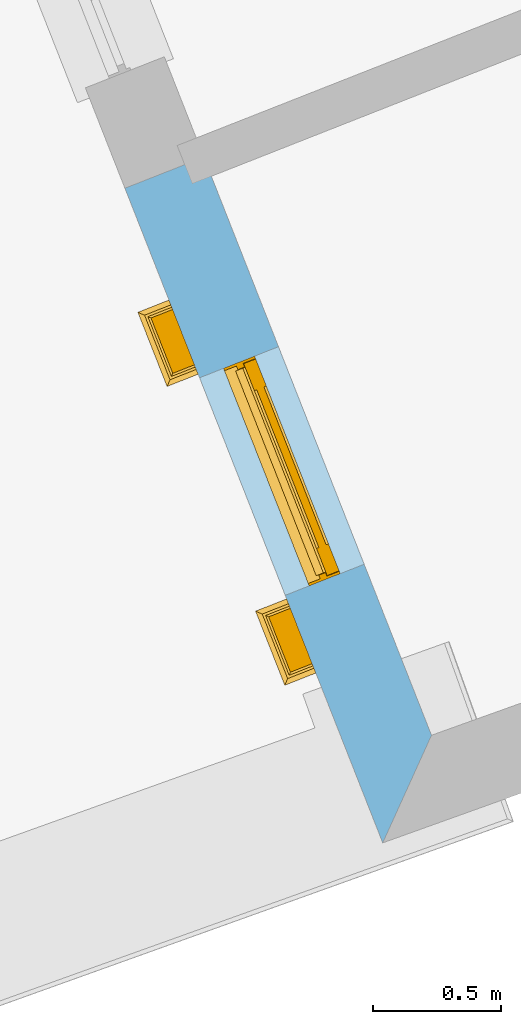
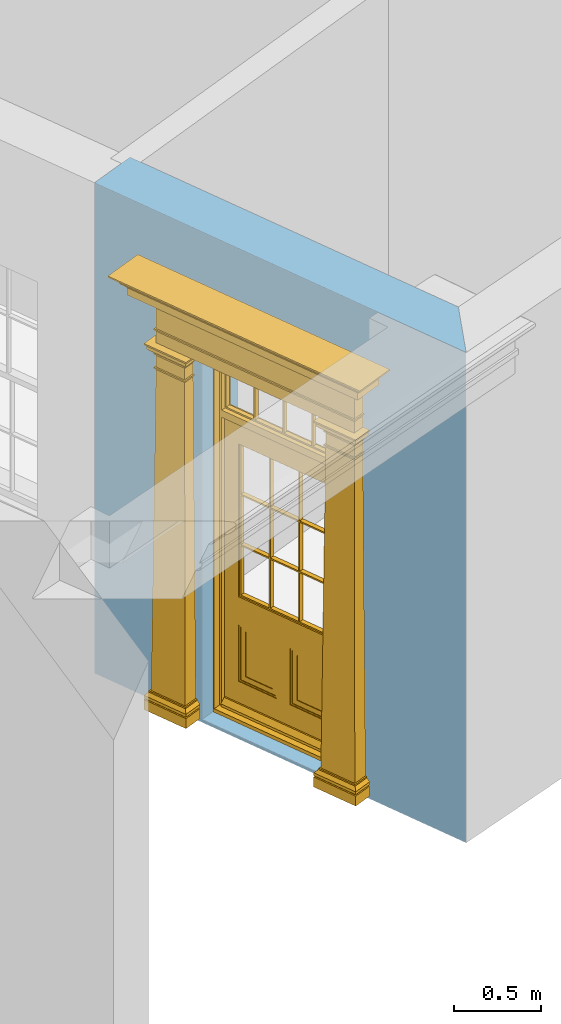
# One storey, part 2 of 8: 1 door, 1 opening, plus 1 element that does not belong to this part.
"""IFC2X3 building model written with IfcOpenShell, lengths in metres."""

import ifcopenshell
import ifcopenshell.guid

model = None  # the IFC model being written
_history = None  # IfcOwnerHistory: only IFC2X3 demands one
_inside = {}  # id of a spatial element -> (the spatial element, [elements in it])
_under = {}  # id of a project, library or spatial element -> (it, [spatial elements below it])
_declared = {}  # id of a project -> (the project, [libraries it declares])
_typed = {}  # id of a type object -> (the type object, [elements of that type])
_made_of = {}  # id of a material, layer set ... -> (it, [elements and type objects made of it])


def new_model(schema):
    """Start an empty IFC model of exactly this schema.

    Asked for "IFC4X3", IfcOpenShell would pick the latest addendum, in which some entities
    have other attributes; the version numbers below select the first issue.
    IFC2X3 requires an IfcOwnerHistory on every rooted entity: one is made here for all.
    """
    global model, _history
    if schema == "IFC4X3":
        model = ifcopenshell.file(schema_version=(4, 3, 0, 0))
    else:
        model = ifcopenshell.file(schema=schema)
    _inside.clear()
    _under.clear()
    _declared.clear()
    _typed.clear()
    _made_of.clear()
    _history = None
    if model.schema == "IFC2X3":
        org = make("IfcOrganization", Name="unknown")
        user = make(
            "IfcPersonAndOrganization",
            ThePerson=make("IfcPerson", FamilyName="unknown"),
            TheOrganization=org,
        )
        app = make(
            "IfcApplication",
            ApplicationDeveloper=org,
            Version="unknown",
            ApplicationFullName="unknown",
            ApplicationIdentifier="unknown",
        )
        _history = make(
            "IfcOwnerHistory",
            OwningUser=user,
            OwningApplication=app,
            ChangeAction="ADDED",
            CreationDate=0,
        )
    return model


def make(cls, **values):
    """One entity of the class cls with the attributes given. An attribute that is None is left unset."""
    return model.create_entity(
        cls, **{name: value for name, value in values.items() if value is not None}
    )


def rooted(cls, **values):
    """An entity with a GlobalId (a new one), such as an element, a storey or a relation."""
    return make(cls, GlobalId=ifcopenshell.guid.new(), OwnerHistory=_history, **values)


def si_unit(unit_type, name, prefix=None):
    """IfcSIUnit, for example si_unit("LENGTHUNIT", "METRE", prefix="MILLI")."""
    return make("IfcSIUnit", UnitType=unit_type, Prefix=prefix, Name=name)


def assignment(units):
    """IfcUnitAssignment: the units of a project."""
    return None if units is None else make("IfcUnitAssignment", Units=units)


def point(xyz):
    """IfcCartesianPoint."""
    return None if xyz is None else make("IfcCartesianPoint", Coordinates=xyz)


def direction(xyz):
    """IfcDirection."""
    return None if xyz is None else make("IfcDirection", DirectionRatios=xyz)


def frame(location, z_axis=None, x_axis=None):
    """IfcAxis2Placement3D, a coordinate frame: its origin and axes. An axis left out is left unset."""
    return make(
        "IfcAxis2Placement3D",
        Location=point(location),
        Axis=direction(z_axis),
        RefDirection=direction(x_axis),
    )


def origin():
    """The frame at (0, 0, 0) with its axes left unset."""
    return frame((0.0, 0.0, 0.0))


def place(relative_to, where):
    """IfcLocalPlacement: puts the frame where relative to a parent placement (None: the world)."""
    return make(
        "IfcLocalPlacement", PlacementRelTo=relative_to, RelativePlacement=where
    )


def context(
    kind, dimensions, precision=None, world=None, true_north=None, identifier=None
):
    """IfcGeometricRepresentationContext, for example the 3D "Model" context."""
    return make(
        "IfcGeometricRepresentationContext",
        ContextIdentifier=identifier,
        ContextType=kind,
        CoordinateSpaceDimension=dimensions,
        Precision=precision,
        WorldCoordinateSystem=world,
        TrueNorth=true_north,
    )


def subcontext(parent, identifier, kind, view, scale=None):
    """IfcGeometricRepresentationSubContext, for example "Body" below "Model"."""
    return make(
        "IfcGeometricRepresentationSubContext",
        ContextIdentifier=identifier,
        ContextType=kind,
        ParentContext=parent,
        TargetScale=scale,
        TargetView=view,
    )


def project(units=None, contexts=None):
    """IfcProject with its units and contexts."""
    return rooted(
        "IfcProject",
        Name="project",
        RepresentationContexts=contexts,
        UnitsInContext=assignment(units),
    )


def spatial(cls, under=None, at=None, **own):
    """A site, building, storey or space (cls), placed at a placement, below another one or the project."""
    s = rooted(cls, ObjectPlacement=at, **own)
    if under is not None:
        _under.setdefault(under.id(), (under, []))[1].append(s)
    return s


def polyline(points):
    """IfcPolyline through the points."""
    return make("IfcPolyline", Points=[point(p) for p in points])


def outline(outer, holes=None, kind="AREA"):
    """IfcArbitraryClosedProfileDef: a profile drawn as a closed curve; with holes, ...WithVoids."""
    if holes is None:
        return make("IfcArbitraryClosedProfileDef", ProfileType=kind, OuterCurve=outer)
    return make(
        "IfcArbitraryProfileDefWithVoids",
        ProfileType=kind,
        OuterCurve=outer,
        InnerCurves=holes,
    )


def extrude(swept, where, along, depth):
    """IfcExtrudedAreaSolid: the profile swept, set in the frame where, extruded along a direction by depth."""
    return make(
        "IfcExtrudedAreaSolid",
        SweptArea=swept,
        Position=where,
        ExtrudedDirection=direction(along),
        Depth=depth,
    )


def faces_of(points, faces, orient=None, outer=None):
    """IfcFace entities. A face is a list of loops; a loop is a list of indices into points, from 0.

    orient and outer hold one flag for each loop. By default every Orientation is true, the
    first loop of a face is its IfcFaceOuterBound and the others are IfcFaceBound.
    """
    made = []
    for i, loops in enumerate(faces):
        bounds = []
        for j, loop in enumerate(loops):
            is_outer = j == 0 if outer is None else outer[i][j]
            bounds.append(
                make(
                    "IfcFaceOuterBound" if is_outer else "IfcFaceBound",
                    Bound=make("IfcPolyLoop", Polygon=[points[k] for k in loop]),
                    Orientation=True if orient is None else orient[i][j],
                )
            )
        made.append(make("IfcFace", Bounds=bounds))
    return made


def faceted_brep(points, faces, orient=None, outer=None, voids=None):
    """IfcFacetedBrep: a solid bounded by flat faces; with voids (closed shells), ...WithVoids."""
    shared = [point(p) for p in points]
    hull = make("IfcClosedShell", CfsFaces=faces_of(shared, faces, orient, outer))
    if voids is None:
        return make("IfcFacetedBrep", Outer=hull)
    return make(
        "IfcFacetedBrepWithVoids",
        Outer=hull,
        Voids=[
            make(cls, CfsFaces=faces_of(shared, fs, o, b)) for cls, fs, o, b in voids
        ],
    )


def shape(context_of_items, identifier, shape_type, items):
    """IfcShapeRepresentation: the items that make up one representation, for example the "Body"."""
    return make(
        "IfcShapeRepresentation",
        ContextOfItems=context_of_items,
        RepresentationIdentifier=identifier,
        RepresentationType=shape_type,
        Items=items,
    )


def material(Name=None, Category=None):
    """IfcMaterial."""
    return make("IfcMaterial", Name=Name, Category=Category)


def layer(
    of_material, thickness, ventilated=None, Name=None, Category=None, Priority=None
):
    """IfcMaterialLayer: one layer of a wall or slab, of a material (None: an air gap)."""
    return make(
        "IfcMaterialLayer",
        Material=of_material,
        LayerThickness=thickness,
        IsVentilated=ventilated,
        Name=Name,
        Category=Category,
        Priority=Priority,
    )


def layer_set(layers, Name=None):
    """IfcMaterialLayerSet."""
    return make("IfcMaterialLayerSet", MaterialLayers=layers, LayerSetName=Name)


def layer_usage(for_layer_set, set_direction, sense, offset, extent=None):
    """IfcMaterialLayerSetUsage: how a layer set lies in its element."""
    return make(
        "IfcMaterialLayerSetUsage",
        ForLayerSet=for_layer_set,
        LayerSetDirection=set_direction,
        DirectionSense=sense,
        OffsetFromReferenceLine=offset,
        ReferenceExtent=extent,
    )


def made_of(thing, what):
    """Note that an element or type object is made of a material, layer set ...; save() writes the relation."""
    if what is not None:
        _made_of.setdefault(what.id(), (what, []))[1].append(thing)
    return thing


def element(
    cls,
    number,
    at=None,
    inside=None,
    cuts=None,
    type_object=None,
    material=None,
    context=None,
    identifier="Body",
    shape_type=None,
    held_by="IfcProductDefinitionShape",
    body=None,
    shapes=None,
    **own,
):
    """One element of the class cls, such as IfcWall. Its Tag is "e" and its number.

    at: its placement. inside: the storey or other place that contains it. cuts: it is an
    opening in that element (IfcRelVoidsElement). A single representation is given by context,
    identifier, shape_type and body (its items); several are given by shapes. held_by: the class
    of the entity that holds the representations. save() writes the other relations.
    """
    e = rooted(cls, Tag="e%d" % number, ObjectPlacement=at, **own)
    if body is not None:
        shapes = [shape(context, identifier, shape_type, body)]
    if shapes is not None:
        e.Representation = make(held_by, Representations=shapes)
    if inside is not None:
        _inside.setdefault(inside.id(), (inside, []))[1].append(e)
    if cuts is not None:
        rooted(
            "IfcRelVoidsElement", RelatingBuildingElement=cuts, RelatedOpeningElement=e
        )
    if type_object is not None:
        _typed.setdefault(type_object.id(), (type_object, []))[1].append(e)
    return made_of(e, material)


def fill(opening, filler):
    """IfcRelFillsElement: the door or window that sits in an opening."""
    return rooted(
        "IfcRelFillsElement",
        RelatingOpeningElement=opening,
        RelatedBuildingElement=filler,
    )


def aggregate(whole, parts):
    """IfcRelAggregates: a whole, such as a stair, and the parts it consists of."""
    return rooted("IfcRelAggregates", RelatingObject=whole, RelatedObjects=parts)


def save(model, path):
    """Write the relations noted so far, then the file.

    IfcRelAggregates (storeys below a building ...), IfcRelContainedInSpatialStructure (elements
    in a storey), IfcRelDefinesByType, IfcRelAssociatesMaterial and IfcRelDeclares: one each for
    every whole, place, type object, material and project.
    """
    for whole, parts in _under.values():
        aggregate(whole, parts)
    for where, things in _inside.values():
        rooted(
            "IfcRelContainedInSpatialStructure",
            RelatedElements=things,
            RelatingStructure=where,
        )
    for kind, things in _typed.values():
        rooted("IfcRelDefinesByType", RelatedObjects=things, RelatingType=kind)
    for what, things in _made_of.values():
        rooted("IfcRelAssociatesMaterial", RelatedObjects=things, RelatingMaterial=what)
    for by, libraries in _declared.values():
        rooted("IfcRelDeclares", RelatingContext=by, RelatedDefinitions=libraries)
    model.write(path)


model = new_model("IFC2X3")

# Units and contexts
model_context = context("Model", 3, world=origin())
body_context = subcontext(model_context, "Body", "Model", "MODEL_VIEW")
ifc_project = project(units=[si_unit("PLANEANGLEUNIT", "RADIAN"), si_unit("MASSUNIT", "GRAM", prefix="KILO"), si_unit("FORCEUNIT", "NEWTON", prefix="KILO"), si_unit("LENGTHUNIT", "METRE")], contexts=[model_context])

# Site, building, storey
site_placement = place(None, origin())
site = spatial("IfcSite", under=ifc_project, at=site_placement, CompositionType="ELEMENT")
building_placement = place(None, origin())
building = spatial("IfcBuilding", under=site, at=building_placement, Name="Building plot-4", CompositionType="ELEMENT")
storey_placement = place(None, frame((0.0, 0.0, 3.0)))
storey = spatial("IfcBuildingStorey", under=building, at=storey_placement, Name="Floor 0", CompositionType="ELEMENT", Elevation=3.0)

# Wall, opening, door
ifc_material = material(Name="Masonry")
ifc_layer = layer(ifc_material, 0.33, ventilated=False)
ifc_layer_set = layer_set([ifc_layer], Name="My Wall")
ifc_layer_usage = layer_usage(ifc_layer_set, "AXIS2", "NEGATIVE", 0.08)
wall_placement = place(storey_placement, origin())
wall = element("IfcWallStandardCase", 1, at=wall_placement, inside=storey, material=ifc_layer_usage, Name="exterior", context=body_context, shape_type="SweptSolid", body=[
    extrude(outline(polyline([(48.7797136330055, 48.8158373917891), (48.4726663727611, 48.69491601247), (49.476039218613, 46.1471210314907), (49.6658207886794, 46.5658070335138), (48.7797136330055, 48.8158373917891)])), origin(), (0.0, 0.0, 1.0), 3.45),
])
opening_placement = place(storey_placement, frame((0.0, 0.0, 0.02)))
opening = element("IfcOpeningElement", 2, at=opening_placement, cuts=wall, Name="Opening", ObjectType="Opening", context=body_context, shape_type="SweptSolid", body=[
    extrude(outline(polyline([(48.7632090415584, 47.9571611924324), (49.0966589057415, 47.1104551111525), (49.4037061659859, 47.2313764904717), (49.0702563018028, 48.0780825717515), (48.7632090415584, 47.9571611924324)])), origin(), (0.0, 0.0, 1.0), 2.545),
])
door_placement = place(storey_placement, frame((48.9958206023496, 48.0487682979772, 0.02), z_axis=(0.0, 0.0, 1.0), x_axis=(0.333449864183081, -0.846706081279855, 0.0)))
door = element("IfcDoor", 3, at=door_placement, inside=storey, Name="house entrance covered", OverallHeight=2.545, OverallWidth=0.91, context=body_context, shape_type="Brep", held_by="IfcProductRepresentation", body=[
    faceted_brep([(-0.305, -0.25, 2.895), (-0.335, -0.25, 2.915), (1.245, -0.25, 2.915), (1.215, -0.25, 2.895), (-0.315, -0.25, 2.895), (-0.335, -0.25, 2.925), (1.245, -0.25, 2.925), (1.225, -0.25, 2.895), (-0.295, -0.25, 2.885), (1.205, -0.25, 2.885), (-0.315, -0.37, 2.895), (-0.305, -0.36, 2.895), (-0.335, -0.39, 2.915), (-0.335, -0.39, 2.925), (-0.395, -0.25, 2.985), (1.305, -0.25, 2.985), (1.245, -0.39, 2.925), (1.245, -0.39, 2.915), (1.225, -0.37, 2.895), (1.215, -0.36, 2.895), (-0.305, -0.25, 2.885), (1.215, -0.25, 2.885), (-0.285, -0.25, 2.875), (1.195, -0.25, 2.875), (-0.305, -0.36, 2.885), (-0.395, -0.45, 2.925), (-0.395, -0.25, 2.925), (-0.405, -0.25, 2.995), (1.315, -0.25, 2.995), (1.305, -0.25, 2.925), (1.305, -0.45, 2.925), (1.215, -0.36, 2.885), (-0.295, -0.35, 2.885), (1.205, -0.35, 2.885), (-0.285, -0.34, 2.875), (1.195, -0.34, 2.875), (-0.275, -0.25, 2.865), (1.185, -0.25, 2.865), (-0.395, -0.45, 2.985), (-0.405, -0.25, 2.985), (-0.415, -0.25, 3.005), (1.325, -0.25, 3.005), (1.315, -0.25, 2.985), (1.305, -0.45, 2.985), (-0.285, -0.25, 2.865), (-0.285, -0.34, 2.865), (1.195, -0.34, 2.865), (1.195, -0.25, 2.865), (-0.275, -0.25, 2.675), (1.185, -0.25, 2.675), (-0.405, -0.46, 2.985), (-0.405, -0.46, 2.995), (-0.415, -0.47, 3.005), (-0.425, -0.25, 3.015), (1.335, -0.25, 3.015), (1.325, -0.47, 3.005), (1.315, -0.46, 2.995), (1.315, -0.46, 2.985), (-0.275, -0.33, 2.865), (1.185, -0.33, 2.865), (-0.275, -0.33, 2.675), (1.185, -0.33, 2.675), (-0.275, -0.25, 2.665), (1.185, -0.25, 2.665), (-0.425, -0.48, 3.005), (-0.425, -0.25, 3.005), (-0.445, -0.25, 3.046), (1.355, -0.25, 3.046), (1.335, -0.25, 3.005), (1.335, -0.48, 3.005), (-0.285, -0.34, 2.675), (-0.285, -0.25, 2.675), (1.195, -0.34, 2.675), (1.195, -0.25, 2.675), (-0.285, -0.25, 2.665), (1.195, -0.25, 2.665), (-0.015, -0.25, 2.575001), (0.925, -0.25, 2.575001), (-0.425, -0.48, 3.015), (-0.435, -0.25, 3.021), (-0.473, -0.25, 3.056), (1.383, -0.25, 3.056), (1.345, -0.25, 3.021), (1.335, -0.48, 3.015), (-0.285, -0.34, 2.665), (1.195, -0.34, 2.665), (-0.275, -0.33, 2.665), (1.185, -0.33, 2.665), (-0.275, -0.25, 2.575001), (1.185, -0.25, 2.575001), (-0.015, -0.33, 2.575001), (0.925, -0.33, 2.575001), (-0.435, -0.49, 3.021), (1.355, -0.5, 3.046), (-0.445, -0.5, 3.046), (1.345, -0.49, 3.021), (-0.473, -0.528, 3.056), (-0.473, -0.25, 3.066), (1.383, -0.25, 3.066), (1.383, -0.528, 3.056), (-0.275, -0.33, 2.575001), (1.185, -0.33, 2.575001), (-0.025, -0.25, 2.565001), (-0.315, -0.25, 2.565001), (1.225, -0.25, 2.565001), (0.935, -0.25, 2.565001), (-0.015, -0.38, 2.565001), (0.925, -0.25, 2.565001), (1.383, -0.528, 3.066), (-0.473, -0.528, 3.066), (-0.325, -0.25, 2.575001), (-0.325, -0.38, 2.575001), (1.235, -0.38, 2.575001), (1.235, -0.25, 2.575001), (-0.015, -0.25, 2.565001), (-0.035, -0.25, 2.535), (-0.305, -0.25, 2.535), (-0.325, -0.25, 2.565001), (1.235, -0.25, 2.565001), (0.945, -0.25, 2.535), (1.215, -0.25, 2.535), (-0.015, -0.38, 2.575001), (0.925, -0.38, 2.575001), (-0.325, -0.38, 2.565001), (1.235, -0.38, 2.565001), (-0.025, -0.37, 2.565001), (-0.025, -0.25, 2.535), (-0.305, -0.25, 2.525), (-0.035, -0.25, 2.525), (-0.315, -0.25, 2.535), (-0.315, -0.37, 2.565001), (1.225, -0.37, 2.565001), (0.935, -0.25, 2.535), (1.225, -0.25, 2.535), (1.215, -0.25, 2.525), (0.945, -0.25, 2.525), (0.935, -0.37, 2.565001), (0.925, -0.38, 2.565001), (-0.025, -0.37, 2.535), (-0.035, -0.36, 2.535), (-0.305, -0.36, 2.525), (-0.305, -0.36, 2.535), (-0.035, -0.36, 2.525), (-0.285, -0.25, 2.505), (-0.055, -0.25, 2.505), (-0.315, -0.37, 2.535), (1.225, -0.37, 2.535), (0.945, -0.36, 2.535), (0.935, -0.37, 2.535), (1.215, -0.36, 2.535), (1.215, -0.36, 2.525), (1.195, -0.25, 2.505), (0.965, -0.25, 2.505), (0.945, -0.36, 2.525), (-0.285, -0.34, 2.505), (-0.055, -0.34, 2.505), (-0.065, -0.25, 2.495), (-0.275, -0.25, 2.495), (1.195, -0.34, 2.505), (1.185, -0.25, 2.495), (0.975, -0.25, 2.495), (0.965, -0.34, 2.505), (-0.285, -0.25, 2.495), (-0.285, -0.34, 2.495), (-0.055, -0.25, 2.495), (-0.055, -0.34, 2.495), (-0.275, -0.25, 2.405), (-0.065, -0.25, 2.405), (1.195, -0.25, 2.495), (1.195, -0.34, 2.495), (1.185, -0.25, 2.405), (0.975, -0.25, 2.405), (0.965, -0.25, 2.495), (0.965, -0.34, 2.495), (-0.275, -0.33, 2.495), (-0.065, -0.33, 2.495), (-0.275, -0.33, 2.405), (-0.065, -0.33, 2.405), (-0.275, -0.25, 2.395), (-0.065, -0.25, 2.395), (1.185, -0.33, 2.495), (1.185, -0.33, 2.405), (1.185, -0.25, 2.395), (0.975, -0.25, 2.395), (0.975, -0.33, 2.405), (0.975, -0.33, 2.495), (-0.285, -0.25, 2.405), (-0.285, -0.34, 2.405), (-0.055, -0.34, 2.405), (-0.055, -0.25, 2.405), (-0.285, -0.25, 2.395), (-0.055, -0.25, 2.395), (-0.295, -0.25, 0.13), (-0.045, -0.25, 0.13), (1.195, -0.34, 2.405), (1.195, -0.25, 2.405), (1.195, -0.25, 2.395), (1.205, -0.25, 0.13), (0.955, -0.25, 0.13), (0.965, -0.25, 2.405), (0.965, -0.25, 2.395), (0.965, -0.34, 2.405), (-0.285, -0.34, 2.395), (-0.055, -0.34, 2.395), (-0.275, -0.33, 2.395), (-0.065, -0.33, 2.395), (-0.295, -0.35, 0.13), (-0.045, -0.35, 0.13), (-0.305, -0.25, 0.12), (-0.035, -0.25, 0.12), (1.195, -0.34, 2.395), (1.185, -0.33, 2.395), (1.205, -0.35, 0.13), (1.215, -0.25, 0.12), (0.945, -0.25, 0.12), (0.955, -0.35, 0.13), (0.975, -0.33, 2.395), (0.965, -0.34, 2.395), (-0.305, -0.25, 0.13), (-0.305, -0.36, 0.13), (-0.035, -0.25, 0.13), (-0.035, -0.36, 0.13), (-0.325, -0.25, 0.1), (-0.015, -0.25, 0.1), (1.215, -0.36, 0.13), (1.215, -0.25, 0.13), (1.235, -0.25, 0.1), (0.925, -0.25, 0.1), (0.945, -0.25, 0.13), (0.945, -0.36, 0.13), (-0.305, -0.36, 0.12), (-0.035, -0.36, 0.12), (-0.325, -0.38, 0.1), (-0.015, -0.38, 0.1), (-0.325, -0.25, 0.08), (-0.015, -0.25, 0.08), (1.215, -0.36, 0.12), (1.235, -0.38, 0.1), (1.235, -0.25, 0.08), (0.925, -0.25, 0.08), (0.925, -0.38, 0.1), (0.945, -0.36, 0.12), (-0.325, -0.38, 0.08), (-0.015, -0.38, 0.08), (-0.315, -0.25, 0.07), (-0.025, -0.25, 0.07), (1.235, -0.38, 0.08), (1.225, -0.25, 0.07), (0.935, -0.25, 0.07), (0.925, -0.38, 0.08), (-0.315, -0.37, 0.07), (-0.025, -0.37, 0.07), (-0.015, -0.25, 0.0), (-0.325, -0.25, 0.0), (1.225, -0.37, 0.07), (1.235, -0.25, 0.0), (0.925, -0.25, 0.0), (0.935, -0.37, 0.07), (-0.325, -0.25, 0.07), (-0.325, -0.38, 0.07), (-0.015, -0.38, 0.07), (-0.015, -0.25, 0.07), (-0.015, -0.38, 0.0), (-0.325, -0.38, 0.0), (1.235, -0.38, 0.07), (1.235, -0.25, 0.07), (1.235, -0.38, 0.0), (0.925, -0.38, 0.0), (0.925, -0.25, 0.07), (0.925, -0.38, 0.07), (0.885, -0.072, 0.025), (0.025, -0.072, 0.025), (0.025, -0.1, 0.025), (0.885, -0.1, 0.025), (0.9, -0.02, 0.025), (0.01, -0.02, 0.025), (0.9, -0.072, 0.025), (0.91, -0.02, 0.0), (0.0, -0.02, 0.0), (0.01, -0.072, 0.025), (0.9, -0.072, 2.07), (0.9, -0.02, 2.07), (0.885, -0.072, 2.055), (0.91, -0.02, 2.08), (0.01, -0.02, 2.07), (0.0, -0.02, 2.08), (0.01, -0.072, 2.07), (0.025, -0.072, 2.055), (0.455, -0.072, 2.07), (0.455, -0.02, 2.07), (0.455, -0.072, 2.055), (0.455, -0.02, 2.08), (0.455, -0.02, 2.105), (0.885, -0.02, 2.105), (0.025, -0.02, 2.105), (0.455, -0.04, 2.105), (0.885, -0.04, 2.105), (0.885, -0.02, 2.52), (0.91, -0.02, 2.545001), (0.025, -0.04, 2.105), (0.0, -0.02, 2.545001), (0.025, -0.02, 2.52), (0.885, -0.04, 2.52), (0.455, -0.02, 2.52), (0.455, -0.02, 2.545001), (0.025, -0.04, 2.52), (0.455, -0.04, 2.52), (0.0, -0.15, 0.0), (0.0, -0.15, 2.08), (0.91, -0.15, 0.0), (0.01, -0.15, 0.025), (0.01, -0.15, 2.08), (0.0, -0.15, 2.545001), (0.9, -0.15, 0.025), (0.91, -0.15, 2.08), (0.01, -0.1, 0.025), (0.01, -0.1, 2.055), (0.01, -0.15, 2.535), (0.455, -0.15, 2.545001), (0.9, -0.15, 2.08), (0.91, -0.15, 2.545001), (0.025, -0.1, 2.055), (0.01, -0.1, 2.105), (0.01, -0.1, 2.535), (0.455, -0.15, 2.535), (0.9, -0.1, 2.055), (0.9, -0.1, 0.025), (0.9, -0.15, 2.535), (0.025, -0.1, 2.105), (0.025, -0.1, 2.52), (0.455, -0.1, 2.535), (0.9, -0.1, 2.105), (0.885, -0.1, 2.055), (0.9, -0.1, 2.535), (0.455, -0.1, 2.055), (0.455, -0.1, 2.105), (0.025, -0.07, 2.105), (0.025, -0.07, 2.52), (0.455, -0.1, 2.52), (0.885, -0.1, 2.105), (0.885, -0.1, 2.52), (0.455, -0.07, 2.105), (0.035, -0.07, 2.51), (0.035, -0.07, 2.115), (0.455, -0.07, 2.52), (0.885, -0.07, 2.52), (0.885, -0.07, 2.105), (0.2475, -0.07, 2.115), (0.2375, -0.07, 2.115), (0.2375, -0.07, 2.51), (0.035, -0.04, 2.51), (0.035, -0.04, 2.115), (0.2475, -0.07, 2.51), (0.875, -0.07, 2.51), (0.875, -0.07, 2.115), (0.6725, -0.07, 2.115), (0.6625, -0.07, 2.115), (0.45, -0.07, 2.115), (0.2375, -0.04, 2.51), (0.2375, -0.04, 2.115), (0.45, -0.07, 2.51), (0.6625, -0.07, 2.51), (0.6725, -0.07, 2.51), (0.875, -0.04, 2.51), (0.875, -0.04, 2.115), (0.46, -0.07, 2.115), (0.45, -0.04, 2.115), (0.2475, -0.04, 2.115), (0.2475, -0.04, 2.51), (0.46, -0.07, 2.51), (0.45, -0.04, 2.51), (0.6725, -0.04, 2.51), (0.6725, -0.04, 2.115), (0.6625, -0.04, 2.51), (0.6625, -0.04, 2.115), (0.46, -0.04, 2.115), (0.46, -0.04, 2.51), (0.898, -0.07, 2.068), (0.898, -0.02, 2.068), (0.012, -0.02, 2.068), (0.012, -0.07, 2.068), (0.898, -0.07, 0.075), (0.898, -0.02, 0.027), (0.012, -0.02, 0.027), (0.012, -0.07, 0.075), (0.898, -0.07, 0.027), (0.012, -0.07, 0.027), (0.883, -0.07, 0.027), (0.883, -0.07, 0.075), (0.027, -0.07, 0.027), (0.027, -0.07, 0.075), (0.883, -0.08, 0.075), (0.883, -0.11, 0.045), (0.027, -0.11, 0.045), (0.027, -0.08, 0.075), (0.027, -0.11, 0.027), (0.883, -0.11, 0.027), (0.745, -0.05, 0.265), (0.545, -0.05, 0.265), (0.545, -0.055, 0.265), (0.745, -0.055, 0.265), (0.745, -0.05, 0.58), (0.545, -0.05, 0.58), (0.545, -0.055, 0.58), (0.515, -0.06, 0.235), (0.775, -0.06, 0.235), (0.745, -0.055, 0.58), (0.515, -0.06, 0.61), (0.515, -0.065, 0.235), (0.775, -0.065, 0.235), (0.775, -0.06, 0.61), (0.515, -0.065, 0.61), (0.785, -0.065, 0.225), (0.505, -0.065, 0.225), (0.775, -0.065, 0.61), (0.505, -0.065, 0.62), (0.785, -0.065, 0.62), (0.505, -0.07, 0.225), (0.785, -0.07, 0.225), (0.505, -0.07, 0.62), (0.785, -0.07, 0.62), (0.405, -0.07, 0.62), (0.405, -0.07, 0.225), (0.785, -0.07, 0.82), (0.125, -0.07, 0.82), (0.405, -0.065, 0.62), (0.405, -0.065, 0.225), (0.125, -0.07, 0.225), (0.785, -0.06, 0.82), (0.125, -0.06, 0.82), (0.125, -0.07, 0.62), (0.125, -0.065, 0.62), (0.395, -0.065, 0.61), (0.395, -0.065, 0.235), (0.125, -0.065, 0.225), (0.785, -0.07, 1.895), (0.558333, -0.06, 0.83), (0.351667, -0.06, 0.83), (0.125, -0.07, 1.895), (0.125, -0.06, 1.895), (0.785, -0.06, 1.895), (0.135, -0.065, 0.61), (0.395, -0.06, 0.61), (0.395, -0.06, 0.235), (0.135, -0.065, 0.235), (0.568333, -0.06, 0.83), (0.558333, -0.03, 0.83), (0.351667, -0.03, 0.83), (0.341667, -0.06, 0.83), (0.135, -0.06, 1.185), (0.135, -0.06, 1.53), (0.775, -0.06, 1.53), (0.775, -0.06, 1.185), (0.135, -0.06, 0.61), (0.365, -0.055, 0.58), (0.365, -0.055, 0.265), (0.135, -0.06, 0.235), (0.568333, -0.06, 1.175), (0.558333, -0.06, 1.175), (0.775, -0.06, 0.83), (0.558333, -0.03, 1.175), (0.785, -0.03, 0.82), (0.125, -0.03, 0.82), (0.351667, -0.03, 1.175), (0.351667, -0.06, 1.175), (0.341667, -0.06, 1.175), (0.135, -0.06, 0.83), (0.135, -0.06, 1.175), (0.135, -0.03, 1.185), (0.135, -0.03, 1.53), (0.135, -0.06, 1.54), (0.351667, -0.06, 1.885), (0.558333, -0.06, 1.885), (0.775, -0.03, 1.53), (0.775, -0.03, 1.185), (0.775, -0.06, 1.175), (0.775, -0.06, 1.54), (0.165, -0.055, 0.58), (0.365, -0.05, 0.58), (0.365, -0.05, 0.265), (0.165, -0.055, 0.265), (0.568333, -0.03, 0.83), (0.568333, -0.03, 1.175), (0.568333, -0.06, 1.185), (0.558333, -0.06, 1.185), (0.775, -0.03, 0.83), (0.785, -0.02, 0.82), (0.125, -0.02, 0.82), (0.341667, -0.03, 0.83), (0.341667, -0.03, 1.175), (0.351667, -0.06, 1.185), (0.341667, -0.06, 1.185), (0.135, -0.03, 0.83), (0.341667, -0.03, 1.185), (0.125, -0.03, 1.895), (0.341667, -0.03, 1.53), (0.341667, -0.06, 1.53), (0.135, -0.06, 1.885), (0.341667, -0.06, 1.54), (0.341667, -0.06, 1.885), (0.558333, -0.03, 1.885), (0.351667, -0.03, 1.885), (0.568333, -0.06, 1.885), (0.785, -0.03, 1.895), (0.568333, -0.03, 1.185), (0.568333, -0.06, 1.53), (0.568333, -0.03, 1.53), (0.568333, -0.06, 1.54), (0.775, -0.06, 1.885), (0.165, -0.05, 0.58), (0.165, -0.05, 0.265), (0.775, -0.03, 1.175), (0.558333, -0.06, 1.53), (0.351667, -0.03, 1.185), (0.558333, -0.03, 1.185), (0.505, -0.02, 0.62), (0.405, -0.02, 0.62), (0.125, -0.02, 1.895), (0.785, -0.02, 1.895), (0.351667, -0.06, 1.53), (0.135, -0.03, 1.175), (0.135, -0.03, 1.54), (0.341667, -0.03, 1.54), (0.135, -0.03, 1.885), (0.351667, -0.06, 1.54), (0.558333, -0.03, 1.54), (0.558333, -0.06, 1.54), (0.351667, -0.03, 1.54), (0.775, -0.03, 1.54), (0.568333, -0.03, 1.54), (0.775, -0.03, 1.885), (0.558333, -0.03, 1.53), (0.405, -0.02, 0.225), (0.505, -0.02, 0.225), (0.125, -0.02, 0.62), (0.785, -0.02, 0.62), (0.351667, -0.03, 1.53), (0.341667, -0.03, 1.885), (0.568333, -0.03, 1.885), (0.405, -0.025, 0.225), (0.405, -0.025, 0.62), (0.505, -0.025, 0.62), (0.505, -0.025, 0.225), (0.125, -0.025, 0.62), (0.785, -0.025, 0.62), (0.395, -0.025, 0.235), (0.395, -0.025, 0.61), (0.125, -0.02, 0.225), (0.125, -0.025, 0.225), (0.515, -0.025, 0.61), (0.515, -0.025, 0.235), (0.785, -0.02, 0.225), (0.785, -0.025, 0.225), (0.135, -0.025, 0.61), (0.775, -0.025, 0.61), (0.135, -0.025, 0.235), (0.395, -0.03, 0.235), (0.395, -0.03, 0.61), (0.515, -0.03, 0.61), (0.515, -0.03, 0.235), (0.775, -0.025, 0.235), (0.135, -0.03, 0.61), (0.775, -0.03, 0.61), (0.135, -0.03, 0.235), (0.365, -0.035, 0.265), (0.365, -0.035, 0.58), (0.545, -0.035, 0.58), (0.545, -0.035, 0.265), (0.775, -0.03, 0.235), (0.165, -0.035, 0.58), (0.745, -0.035, 0.58), (0.165, -0.035, 0.265), (0.365, -0.04, 0.58), (0.365, -0.04, 0.265), (0.545, -0.04, 0.58), (0.545, -0.04, 0.265), (0.745, -0.035, 0.265), (0.165, -0.04, 0.58), (0.745, -0.04, 0.58), (0.165, -0.04, 0.265), (0.745, -0.04, 0.265)], [[[0, 1, 2, 3]], [[0, 4, 1]], [[1, 5, 6, 2]], [[7, 3, 2]], [[8, 0, 3, 9]], [[10, 4, 0, 11]], [[12, 1, 4, 10]], [[1, 12, 13, 5]], [[5, 14, 15, 6]], [[6, 16, 17, 2]], [[7, 18, 19, 3]], [[2, 17, 18, 7]], [[8, 20, 0]], [[21, 9, 3]], [[22, 8, 9, 23]], [[11, 0, 20, 24]], [[10, 11, 19, 18]], [[12, 10, 18, 17]], [[25, 26, 5, 13]], [[13, 12, 17, 16]], [[5, 26, 14]], [[14, 27, 28, 15]], [[29, 6, 15]], [[29, 30, 16, 6]], [[3, 19, 31, 21]], [[24, 20, 8, 32]], [[21, 31, 33, 9]], [[32, 8, 22, 34]], [[9, 33, 35, 23]], [[36, 22, 23, 37]], [[11, 24, 31, 19]], [[38, 14, 26, 25]], [[25, 13, 16, 30]], [[14, 39, 27]], [[27, 40, 41, 28]], [[42, 15, 28]], [[15, 43, 30, 29]], [[24, 32, 33, 31]], [[34, 22, 44, 45]], [[32, 34, 35, 33]], [[23, 35, 46, 47]], [[36, 44, 22]], [[47, 37, 23]], [[48, 36, 37, 49]], [[50, 39, 14, 38]], [[38, 25, 30, 43]], [[51, 27, 39, 50]], [[52, 40, 27, 51]], [[40, 53, 54, 41]], [[41, 55, 56, 28]], [[42, 57, 43, 15]], [[28, 56, 57, 42]], [[45, 44, 36, 58]], [[34, 45, 46, 35]], [[47, 46, 59, 37]], [[60, 58, 36, 48]], [[59, 61, 49, 37]], [[62, 48, 49, 63]], [[50, 38, 43, 57]], [[51, 50, 57, 56]], [[64, 65, 40, 52]], [[52, 51, 56, 55]], [[40, 65, 53]], [[53, 66, 67, 54]], [[68, 41, 54]], [[68, 69, 55, 41]], [[45, 58, 59, 46]], [[58, 60, 61, 59]], [[70, 60, 48, 71]], [[61, 72, 73, 49]], [[71, 48, 62, 74]], [[49, 73, 75, 63]], [[76, 62, 63, 77]], [[78, 53, 65, 64]], [[64, 52, 55, 69]], [[53, 79, 66]], [[66, 80, 81, 67]], [[82, 54, 67]], [[54, 83, 69, 68]], [[60, 70, 72, 61]], [[84, 70, 71, 74]], [[72, 85, 75, 73]], [[86, 84, 74, 62]], [[85, 87, 63, 75]], [[76, 88, 62]], [[89, 77, 63]], [[90, 76, 77, 91]], [[92, 79, 53, 78]], [[93, 94, 92, 95]], [[64, 69, 83, 78]], [[94, 66, 79, 92]], [[80, 66, 94, 96]], [[80, 97, 98, 81]], [[99, 93, 67, 81]], [[82, 95, 83, 54]], [[67, 93, 95, 82]], [[92, 78, 83, 95]], [[70, 84, 85, 72]], [[84, 86, 87, 85]], [[100, 86, 62, 88]], [[87, 101, 89, 63]], [[88, 76, 102, 103]], [[77, 89, 104, 105]], [[76, 90, 106]], [[91, 77, 107]], [[86, 90, 91, 87]], [[108, 98, 97, 109]], [[109, 97, 80, 96]], [[98, 108, 99, 81]], [[86, 100, 90]], [[100, 88, 110, 111]], [[101, 87, 91]], [[89, 101, 112, 113]], [[76, 114, 102]], [[102, 115, 116, 103]], [[110, 88, 103, 117]], [[89, 113, 118, 104]], [[119, 105, 104, 120]], [[107, 77, 105]], [[90, 121, 106]], [[106, 114, 76]], [[107, 122, 91]], [[109, 96, 99, 108]], [[96, 94, 93, 99]], [[111, 121, 90, 100]], [[110, 117, 123, 111]], [[122, 112, 101, 91]], [[118, 113, 112, 124]], [[102, 114, 106, 125]], [[102, 126, 115]], [[127, 116, 115, 128]], [[103, 116, 129]], [[117, 103, 130, 123]], [[104, 118, 124, 131]], [[119, 132, 105]], [[104, 133, 120]], [[120, 134, 135, 119]], [[107, 105, 136, 137]], [[106, 121, 111, 123]], [[107, 137, 122]], [[122, 137, 124, 112]], [[130, 125, 106, 123]], [[126, 102, 125, 138]], [[115, 126, 138, 139]], [[116, 127, 140, 141]], [[128, 115, 139, 142]], [[143, 127, 128, 144]], [[129, 116, 141, 145]], [[103, 129, 145, 130]], [[136, 131, 124, 137]], [[133, 104, 131, 146]], [[132, 119, 147, 148]], [[105, 132, 148, 136]], [[120, 133, 146, 149]], [[134, 120, 149, 150]], [[134, 151, 152, 135]], [[119, 135, 153, 147]], [[138, 125, 130, 145]], [[141, 139, 138, 145]], [[127, 143, 154, 140]], [[142, 139, 141, 140]], [[144, 128, 142, 155]], [[156, 157, 143, 144]], [[136, 148, 146, 131]], [[147, 149, 146, 148]], [[147, 153, 150, 149]], [[151, 134, 150, 158]], [[159, 160, 152, 151]], [[135, 152, 161, 153]], [[143, 162, 163, 154]], [[140, 154, 155, 142]], [[164, 144, 155, 165]], [[166, 157, 156, 167]], [[157, 162, 143]], [[144, 164, 156]], [[158, 150, 153, 161]], [[168, 151, 158, 169]], [[159, 170, 171, 160]], [[172, 152, 160]], [[168, 159, 151]], [[152, 172, 173, 161]], [[174, 163, 162, 157]], [[155, 154, 163, 165]], [[164, 165, 175, 156]], [[157, 166, 176, 174]], [[167, 156, 175, 177]], [[178, 166, 167, 179]], [[158, 161, 173, 169]], [[169, 180, 159, 168]], [[170, 159, 180, 181]], [[170, 182, 183, 171]], [[160, 171, 184, 185]], [[173, 172, 160, 185]], [[174, 175, 165, 163]], [[186, 187, 176, 166]], [[174, 176, 177, 175]], [[177, 188, 189, 167]], [[178, 190, 186, 166]], [[167, 189, 191, 179]], [[192, 178, 179, 193]], [[185, 180, 169, 173]], [[181, 180, 185, 184]], [[194, 195, 170, 181]], [[196, 182, 170, 195]], [[182, 197, 198, 183]], [[199, 171, 183, 200]], [[201, 184, 171, 199]], [[190, 202, 187, 186]], [[177, 176, 187, 188]], [[191, 189, 188, 203]], [[204, 202, 190, 178]], [[191, 203, 205, 179]], [[178, 192, 206, 204]], [[193, 179, 205, 207]], [[208, 192, 193, 209]], [[181, 184, 201, 194]], [[210, 196, 195, 194]], [[210, 211, 182, 196]], [[211, 212, 197, 182]], [[197, 213, 214, 198]], [[183, 198, 215, 216]], [[217, 200, 183, 216]], [[199, 200, 217, 201]], [[202, 203, 188, 187]], [[204, 205, 203, 202]], [[192, 218, 219, 206]], [[204, 206, 207, 205]], [[220, 193, 207, 221]], [[208, 218, 192]], [[193, 220, 209]], [[222, 208, 209, 223]], [[217, 210, 194, 201]], [[216, 211, 210, 217]], [[212, 211, 216, 215]], [[212, 224, 225, 197]], [[225, 213, 197]], [[213, 226, 227, 214]], [[228, 198, 214]], [[198, 228, 229, 215]], [[218, 208, 230, 219]], [[221, 207, 206, 219]], [[209, 220, 221, 231]], [[208, 222, 232, 230]], [[223, 209, 231, 233]], [[234, 222, 223, 235]], [[224, 212, 215, 229]], [[213, 225, 224, 236]], [[226, 213, 236, 237]], [[226, 238, 239, 227]], [[214, 227, 240, 241]], [[228, 214, 241, 229]], [[231, 221, 219, 230]], [[234, 242, 232, 222]], [[233, 231, 230, 232]], [[235, 223, 233, 243]], [[244, 234, 235, 245]], [[229, 241, 236, 224]], [[241, 240, 237, 236]], [[246, 238, 226, 237]], [[238, 247, 248, 239]], [[227, 239, 249, 240]], [[234, 244, 250, 242]], [[243, 233, 232, 242]], [[245, 235, 243, 251]], [[252, 253, 244, 245]], [[240, 249, 246, 237]], [[247, 238, 246, 254]], [[255, 256, 248, 247]], [[239, 248, 257, 249]], [[258, 259, 250, 244]], [[242, 250, 251, 243]], [[251, 260, 261, 245]], [[262, 263, 253, 252]], [[253, 258, 244]], [[245, 261, 252]], [[254, 246, 249, 257]], [[264, 265, 247, 254]], [[266, 267, 256, 255]], [[268, 248, 256]], [[265, 255, 247]], [[269, 257, 248, 268]], [[258, 253, 263, 259]], [[251, 250, 259, 260]], [[252, 261, 260, 262]], [[259, 263, 262, 260]], [[254, 257, 269, 264]], [[255, 265, 264, 266]], [[266, 264, 269, 267]], [[268, 256, 267, 269]], [[270, 271, 272, 273]], [[271, 270, 274, 275]], [[276, 274, 270]], [[274, 277, 278, 275]], [[279, 271, 275]], [[280, 281, 274, 276]], [[276, 270, 282, 280]], [[281, 283, 277, 274]], [[284, 275, 278, 285]], [[286, 287, 271, 279]], [[275, 284, 286, 279]], [[280, 288, 289, 281]], [[282, 290, 288, 280]], [[281, 289, 291, 283]], [[285, 291, 289, 284]], [[286, 288, 290, 287]], [[284, 289, 288, 286]], [[283, 291, 292, 293]], [[294, 292, 291, 285]], [[293, 292, 295, 296]], [[283, 293, 297, 298]], [[299, 295, 292, 294]], [[294, 285, 300, 301]], [[296, 302, 297, 293]], [[297, 303, 304, 298]], [[305, 299, 294, 301]], [[300, 304, 303, 301]], [[302, 306, 303, 297]], [[301, 303, 306, 305]], [[285, 278, 307, 308]], [[309, 307, 278, 277]], [[307, 310, 311, 308]], [[285, 308, 312, 300]], [[307, 309, 313, 310]], [[314, 309, 277, 283]], [[315, 316, 311, 310]], [[312, 308, 311, 317]], [[312, 318, 304, 300]], [[319, 313, 309, 314]], [[310, 313, 273, 272]], [[320, 314, 283, 298]], [[272, 321, 316, 315]], [[322, 311, 316]], [[315, 310, 272]], [[317, 311, 322, 323]], [[317, 324, 318, 312]], [[298, 304, 318, 320]], [[313, 319, 325, 326]], [[327, 319, 314, 320]], [[326, 273, 313]], [[287, 321, 272, 271]], [[322, 316, 321, 328]], [[323, 322, 328, 329]], [[323, 330, 324, 317]], [[320, 318, 324, 327]], [[331, 325, 319]], [[326, 325, 332, 273]], [[333, 331, 319, 327]], [[287, 290, 334, 321]], [[321, 334, 335, 328]], [[336, 337, 329, 328]], [[329, 338, 330, 323]], [[327, 324, 330, 333]], [[339, 332, 325, 331]], [[282, 270, 273, 332]], [[340, 339, 331, 333]], [[332, 334, 290, 282]], [[339, 335, 334, 332]], [[328, 335, 341, 336]], [[342, 337, 336, 343]], [[337, 344, 338, 329]], [[333, 330, 338, 340]], [[339, 340, 345, 346]], [[346, 341, 335, 339]], [[341, 347, 348, 336]], [[342, 349, 337]], [[343, 336, 348]], [[350, 342, 343, 351]], [[349, 352, 344, 337]], [[340, 338, 344, 345]], [[346, 345, 353, 354]], [[355, 356, 341, 346]], [[357, 347, 341]], [[352, 349, 348, 347]], [[349, 342, 350, 358]], [[343, 348, 359, 351]], [[305, 350, 351, 299]], [[360, 344, 352]], [[345, 344, 361, 362]], [[353, 345, 362]], [[353, 363, 364, 354]], [[354, 355, 346]], [[362, 361, 356, 355]], [[365, 341, 356]], [[347, 357, 366, 367]], [[365, 357, 341]], [[358, 359, 348, 349]], [[367, 368, 352, 347]], [[350, 305, 358]], [[351, 359, 299]], [[360, 369, 344]], [[360, 352, 368, 370]], [[369, 361, 344]], [[362, 371, 363, 353]], [[302, 296, 364, 363]], [[372, 355, 354, 364]], [[373, 374, 356, 361]], [[372, 371, 362, 355]], [[365, 356, 374, 375]], [[370, 366, 357, 360]], [[366, 295, 367]], [[369, 360, 357, 365]], [[358, 368, 367, 359]], [[305, 306, 368, 358]], [[359, 367, 295, 299]], [[368, 306, 370]], [[361, 369, 376, 373]], [[363, 371, 302]], [[364, 296, 372]], [[373, 371, 372, 374]], [[374, 295, 375]], [[375, 376, 369, 365]], [[370, 376, 375, 366]], [[375, 295, 366]], [[370, 306, 376]], [[376, 306, 373]], [[371, 373, 306, 302]], [[296, 295, 374, 372]], [[377, 378, 379, 380]], [[381, 382, 378, 377]], [[383, 384, 380, 379]], [[385, 382, 381]], [[383, 386, 384]], [[382, 385, 387]], [[388, 387, 385, 381]], [[386, 383, 389]], [[384, 386, 389, 390]], [[383, 382, 387, 389]], [[391, 392, 387, 388]], [[390, 389, 393, 394]], [[395, 389, 387, 396]], [[396, 387, 392]], [[395, 393, 389]], [[397, 398, 399, 400]], [[397, 401, 402, 398]], [[402, 403, 399, 398]], [[400, 399, 404, 405]], [[406, 401, 397, 400]], [[406, 403, 402, 401]], [[399, 403, 407, 404]], [[405, 404, 408, 409]], [[405, 410, 406, 400]], [[410, 407, 403, 406]], [[404, 407, 411, 408]], [[412, 409, 408, 413]], [[409, 414, 410, 405]], [[414, 411, 407, 410]], [[415, 413, 408, 411]], [[412, 416, 414, 409]], [[412, 413, 417, 418]], [[411, 414, 416, 415]], [[413, 415, 419, 417]], [[418, 420, 416, 412]], [[388, 381, 418, 417]], [[420, 419, 415, 416]], [[417, 419, 421, 422]], [[420, 418, 381]], [[390, 388, 417, 422]], [[419, 420, 423]], [[423, 424, 421, 419]], [[422, 421, 425, 426]], [[420, 381, 377, 423]], [[394, 391, 388, 390]], [[390, 422, 427, 384]], [[428, 429, 424, 423]], [[421, 424, 430]], [[421, 430, 431, 425]], [[432, 433, 426, 425]], [[426, 434, 427, 422]], [[377, 435, 423]], [[393, 392, 391, 394]], [[427, 430, 384]], [[429, 428, 436, 437]], [[438, 424, 429, 439]], [[423, 435, 440, 428]], [[380, 384, 430, 424]], [[434, 431, 430, 427]], [[425, 431, 441, 432]], [[433, 432, 442, 443]], [[444, 434, 426, 433]], [[438, 435, 377, 380]], [[392, 393, 395, 396]], [[445, 436, 428]], [[437, 436, 446, 447]], [[437, 448, 429]], [[438, 380, 424]], [[439, 429, 449, 450]], [[435, 438, 439, 440]], [[451, 452, 428, 440]], [[444, 441, 431, 434]], [[432, 441, 453, 442]], [[443, 442, 454, 455]], [[443, 456, 444, 433]], [[445, 457, 458, 436]], [[445, 428, 459]], [[436, 458, 460, 446]], [[461, 462, 447, 446]], [[447, 463, 464, 437]], [[437, 464, 465, 448]], [[448, 466, 429]], [[467, 449, 429]], [[450, 449, 468, 469]], [[470, 439, 450]], [[440, 439, 471, 472]], [[473, 474, 452, 451]], [[475, 428, 452]], [[476, 451, 440]], [[456, 453, 441, 444]], [[442, 453, 477, 454]], [[454, 478, 479, 455]], [[455, 480, 456, 443]], [[481, 482, 457, 445]], [[458, 457, 483, 484]], [[459, 428, 475]], [[485, 481, 445, 459]], [[460, 458, 464, 463]], [[446, 460, 482, 481]], [[486, 487, 462, 461]], [[462, 488, 447]], [[481, 461, 446]], [[488, 489, 463, 447]], [[465, 464, 490, 491]], [[448, 465, 489, 488]], [[466, 448, 488, 492]], [[466, 467, 429]], [[491, 449, 467, 465]], [[491, 493, 468, 449]], [[469, 468, 462, 494]], [[495, 496, 450, 469]], [[497, 439, 470]], [[498, 470, 450, 496]], [[499, 471, 439]], [[500, 472, 471, 501]], [[502, 440, 472]], [[503, 461, 474, 473]], [[504, 483, 452, 474]], [[505, 506, 473, 451]], [[452, 483, 457, 475]], [[476, 507, 505, 451]], [[476, 440, 508]], [[480, 477, 453, 456]], [[454, 477, 509, 478]], [[479, 478, 509, 510]], [[479, 510, 480, 455]], [[457, 482, 511, 475]], [[512, 484, 483, 505]], [[484, 490, 464, 458]], [[459, 475, 511, 485]], [[481, 485, 461]], [[513, 514, 460, 463]], [[482, 460, 514, 504]], [[515, 516, 487, 486]], [[494, 462, 487, 517]], [[518, 486, 461, 503]], [[462, 492, 488]], [[463, 489, 493, 513]], [[496, 491, 490, 519]], [[489, 465, 467, 520]], [[492, 520, 467, 466]], [[495, 493, 491, 496]], [[489, 520, 468, 493]], [[468, 520, 462]], [[521, 469, 494]], [[495, 469, 521, 522]], [[499, 439, 497]], [[470, 521, 523, 497]], [[498, 522, 521, 470]], [[496, 519, 524, 498]], [[471, 499, 498, 524]], [[525, 526, 472, 500]], [[524, 527, 501, 471]], [[494, 503, 500, 501]], [[502, 508, 440]], [[502, 472, 526, 507]], [[511, 474, 461]], [[528, 503, 473]], [[505, 483, 504, 506]], [[504, 474, 511, 482]], [[529, 528, 473, 506]], [[529, 507, 476, 528]], [[512, 505, 507, 526]], [[528, 476, 508, 530]], [[509, 477, 480, 510]], [[531, 514, 484, 512]], [[484, 514, 513, 490]], [[485, 511, 461]], [[506, 504, 514, 531]], [[532, 516, 515, 533]], [[516, 534, 487]], [[515, 486, 535]], [[487, 379, 517]], [[503, 494, 517, 518]], [[486, 518, 378]], [[492, 462, 520]], [[536, 513, 493, 495]], [[519, 490, 513, 536]], [[494, 523, 521]], [[536, 495, 522, 527]], [[537, 499, 497, 523]], [[522, 498, 499, 537]], [[526, 524, 519, 512]], [[526, 525, 527, 524]], [[529, 525, 500, 538]], [[527, 522, 537, 501]], [[538, 500, 503]], [[501, 537, 494]], [[502, 538, 530, 508]], [[507, 529, 538, 502]], [[528, 530, 503]], [[506, 531, 525, 529]], [[531, 512, 519, 536]], [[539, 540, 516, 532]], [[533, 515, 541, 542]], [[533, 382, 383, 532]], [[540, 543, 534, 516]], [[383, 379, 487, 534]], [[486, 378, 382, 535]], [[544, 541, 515, 535]], [[379, 378, 518, 517]], [[537, 523, 494]], [[527, 525, 531, 536]], [[530, 538, 503]], [[540, 539, 545, 546]], [[532, 547, 548, 539]], [[549, 550, 542, 541]], [[551, 533, 542, 552]], [[533, 551, 382]], [[547, 532, 383]], [[553, 543, 540, 546]], [[547, 534, 543, 548]], [[547, 383, 534]], [[535, 382, 551]], [[544, 554, 549, 541]], [[552, 544, 535, 551]], [[555, 545, 539, 548]], [[556, 557, 546, 545]], [[550, 549, 558, 559]], [[552, 542, 550, 560]], [[548, 543, 553, 555]], [[557, 561, 553, 546]], [[560, 554, 544, 552]], [[562, 558, 549, 554]], [[545, 555, 563, 556]], [[564, 565, 557, 556]], [[559, 558, 566, 567]], [[560, 550, 559, 568]], [[555, 553, 561, 563]], [[565, 569, 561, 557]], [[568, 562, 554, 560]], [[570, 566, 558, 562]], [[556, 563, 571, 564]], [[572, 565, 564, 573]], [[566, 574, 575, 567]], [[568, 559, 567, 576]], [[563, 561, 569, 571]], [[572, 577, 569, 565]], [[576, 570, 562, 568]], [[578, 574, 566, 570]], [[564, 571, 579, 573]], [[579, 577, 572, 573]], [[575, 574, 578, 580]], [[576, 567, 575, 580]], [[569, 577, 579, 571]], [[578, 570, 576, 580]]]),
])
fill(opening, door)

save(model, "model.ifc")
